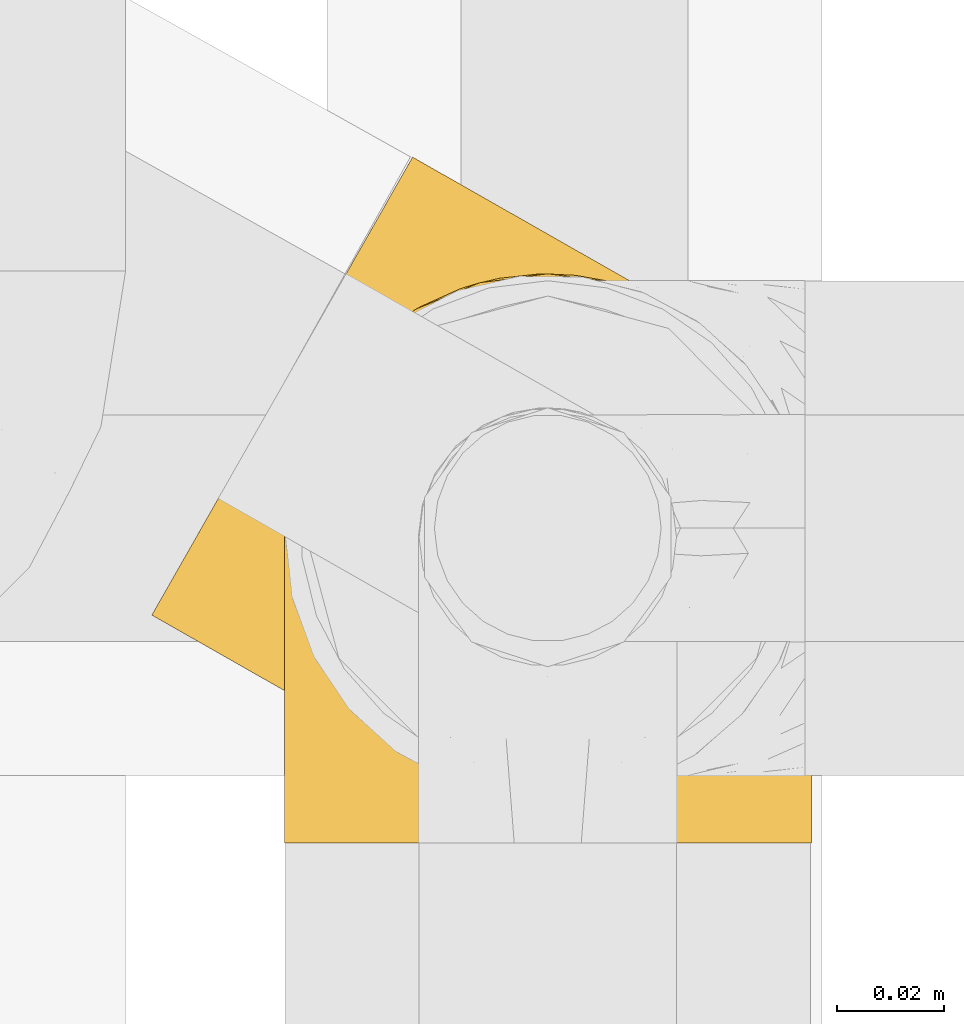
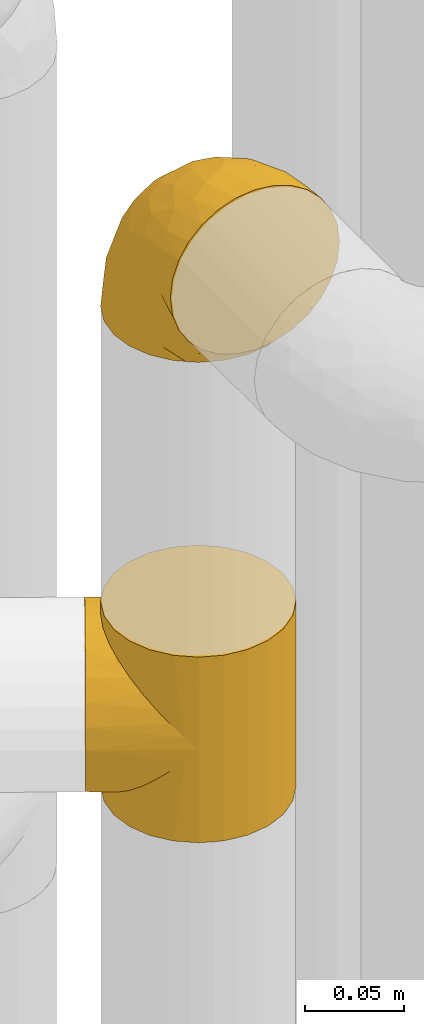
# One storey, part 169 of 827: 2 coverings.
"""IFC2X3 building model written with IfcOpenShell, lengths in millimetres."""

from ifc_helpers import new_model, entity, si_unit, converted_unit, derived_unit, direction, frame, origin, place, context, subcontext, project, spatial, faceted_brep, element, save


model = new_model("IFC2X3")

# Units and contexts
model_context = context("Model", 3, precision=0.01, world=origin(), true_north=direction((6.12303176911189e-17, 1.0)))
body_context = subcontext(model_context, "Body", "Model", "MODEL_VIEW")
ifc_project = project(units=[si_unit("LENGTHUNIT", "METRE", prefix="MILLI"), si_unit("AREAUNIT", "SQUARE_METRE"), si_unit("VOLUMEUNIT", "CUBIC_METRE"), converted_unit("PLANEANGLEUNIT", "DEGREE", entity("IfcRatioMeasure", 0.0174532925199433), si_unit("PLANEANGLEUNIT", "RADIAN"), dimensions=[0, 0, 0, 0, 0, 0, 0]), si_unit("MASSUNIT", "GRAM", prefix="KILO"), derived_unit("MASSDENSITYUNIT", [(si_unit("MASSUNIT", "GRAM", prefix="KILO"), 1), (si_unit("LENGTHUNIT", "METRE"), -3)]), derived_unit("MOMENTOFINERTIAUNIT", [(si_unit("LENGTHUNIT", "METRE"), 4)]), si_unit("TIMEUNIT", "SECOND"), si_unit("FREQUENCYUNIT", "HERTZ"), si_unit("THERMODYNAMICTEMPERATUREUNIT", "DEGREE_CELSIUS"), derived_unit("THERMALTRANSMITTANCEUNIT", [(si_unit("MASSUNIT", "GRAM", prefix="KILO"), 1), (si_unit("THERMODYNAMICTEMPERATUREUNIT", "KELVIN"), -1), (si_unit("TIMEUNIT", "SECOND"), -3)]), derived_unit("VOLUMETRICFLOWRATEUNIT", [(si_unit("LENGTHUNIT", "METRE"), 3), (si_unit("TIMEUNIT", "SECOND"), -1)]), derived_unit("MASSFLOWRATEUNIT", [(si_unit("MASSUNIT", "GRAM", prefix="KILO"), 1), (si_unit("TIMEUNIT", "SECOND"), -1)]), derived_unit("ROTATIONALFREQUENCYUNIT", [(si_unit("TIMEUNIT", "SECOND"), -1)]), si_unit("ELECTRICCURRENTUNIT", "AMPERE"), si_unit("ELECTRICVOLTAGEUNIT", "VOLT"), si_unit("POWERUNIT", "WATT"), si_unit("FORCEUNIT", "NEWTON", prefix="KILO"), si_unit("ILLUMINANCEUNIT", "LUX"), si_unit("LUMINOUSFLUXUNIT", "LUMEN"), si_unit("LUMINOUSINTENSITYUNIT", "CANDELA"), derived_unit("USERDEFINED", [(si_unit("MASSUNIT", "GRAM", prefix="KILO"), -1), (si_unit("LENGTHUNIT", "METRE"), -2), (si_unit("TIMEUNIT", "SECOND"), 3), (si_unit("LUMINOUSFLUXUNIT", "LUMEN"), 1)]), derived_unit("LINEARVELOCITYUNIT", [(si_unit("LENGTHUNIT", "METRE"), 1), (si_unit("TIMEUNIT", "SECOND"), -1)]), si_unit("PRESSUREUNIT", "PASCAL"), derived_unit("USERDEFINED", [(si_unit("LENGTHUNIT", "METRE"), -2), (si_unit("MASSUNIT", "GRAM", prefix="KILO"), 1), (si_unit("TIMEUNIT", "SECOND"), -2)]), derived_unit("LINEARFORCEUNIT", [(si_unit("MASSUNIT", "GRAM", prefix="KILO"), 1), (si_unit("LENGTHUNIT", "METRE"), 1), (si_unit("TIMEUNIT", "SECOND"), -2), (si_unit("LENGTHUNIT", "METRE"), -1)]), derived_unit("PLANARFORCEUNIT", [(si_unit("MASSUNIT", "GRAM", prefix="KILO"), 1), (si_unit("LENGTHUNIT", "METRE"), 1), (si_unit("TIMEUNIT", "SECOND"), -2), (si_unit("LENGTHUNIT", "METRE"), -2)])], contexts=[model_context])

# Site, building, storey
site_placement = place(None, origin())
site = spatial("IfcSite", under=ifc_project, at=site_placement, CompositionType="ELEMENT")
building_placement = place(site_placement, origin())
building = spatial("IfcBuilding", under=site, at=building_placement, CompositionType="ELEMENT")
storey_placement = place(building_placement, frame((0.0, 0.0, 28200.0)))
storey = spatial("IfcBuildingStorey", under=building, at=storey_placement, Name="08", CompositionType="ELEMENT", Elevation=28200.0)

# Coverings
covering_1_placement = place(storey_placement, frame((35649.59, 12703.72, 2248.0)))
element("IfcCovering", 1, at=covering_1_placement, inside=storey, Name=":ADSK_", ObjectType=":ADSK_", PredefinedType="INSULATION", context=body_context, shape_type="Brep", body=[
    faceted_brep([(93.79, 96.34, 50.38), (99.76, 93.46, 0.0), (87.88, 98.3, 0.0), (75.15, 99.89, 0.0), (80.71, 99.61, 37.4), (66.46, 99.07, 25.28), (62.44, 98.14, 0.0), (73.7, 99.86, 31.18), (99.76, 93.46, 57.0), (93.79, 96.34, 63.62), (99.76, 93.46, 114.0), (35.42, 78.88, 8.29), (36.61, 80.17, 0.0), (34.67, 77.62, 0.0), (87.43, 98.41, 43.83), (32.73, 75.06, 7.85), (32.73, 75.06, 0.0), (34.67, 77.62, 114.0), (32.73, 75.06, 106.15), (32.73, 75.06, 114.0), (59.07, 97.09, 19.84), (50.62, 93.16, 0.0), (45.55, 89.22, 0.0), (40.48, 85.29, 0.0), (41.34, 85.85, 10.0), (38.11, 82.7, 8.74), (51.69, 93.77, 15.07), (44.58, 89.0, 11.25), (38.55, 82.73, 0.0), (31.52, 72.09, 0.0), (30.32, 69.12, 0.0), (30.66, 70.32, 8.4), (28.59, 65.57, 8.94), (29.11, 66.15, 0.0), (27.9, 63.18, 0.0), (26.56, 55.83, 12.0), (27.1, 56.81, 0.0), (26.3, 50.45, 0.0), (27.57, 60.7, 10.47), (26.48, 46.46, 16.57), (27.17, 44.09, 0.0), (28.03, 37.82, 22.18), (26.52, 51.14, 14.29), (31.7, 72.69, 8.12), (28.05, 37.74, 0.0), (30.87, 30.04, 28.5), (33.03, 25.91, 0.0), (34.77, 23.16, 35.29), (40.9, 15.78, 0.0), (45.02, 12.15, 49.65), (51.13, 8.03, 0.0), (31.7, 72.69, 105.88), (39.53, 17.2, 42.38), (51.13, 8.03, 57.0), (45.02, 12.15, 64.35), (51.13, 8.03, 114.0), (100.28, 8.33, 114.0), (110.41, 16.2, 114.0), (118.16, 26.43, 114.0), (123.0, 38.31, 114.0), (124.6, 51.04, 114.0), (122.84, 63.75, 114.0), (117.86, 75.58, 114.0), (109.99, 85.71, 114.0), (87.88, 98.3, 114.0), (75.15, 99.89, 114.0), (62.44, 98.14, 114.0), (50.62, 93.16, 114.0), (45.55, 89.22, 114.0), (40.48, 85.29, 114.0), (38.55, 82.73, 114.0), (36.61, 80.17, 114.0), (31.52, 72.09, 114.0), (30.32, 69.12, 114.0), (29.11, 66.15, 114.0), (27.9, 63.18, 114.0), (27.1, 56.81, 114.0), (26.3, 50.45, 114.0), (27.17, 44.09, 114.0), (28.05, 37.74, 114.0), (33.03, 25.91, 114.0), (40.9, 15.78, 114.0), (63.01, 3.19, 114.0), (75.74, 1.6, 114.0), (88.45, 3.35, 114.0), (109.99, 85.71, 0.0), (117.86, 75.58, 0.0), (122.84, 63.75, 0.0), (124.6, 51.04, 0.0), (123.0, 38.31, 0.0), (118.16, 26.43, 0.0), (110.41, 16.2, 0.0), (100.28, 8.33, 0.0), (88.45, 3.35, 0.0), (75.74, 1.6, 0.0), (63.01, 3.19, 0.0), (87.43, 98.41, 70.17), (80.71, 99.61, 76.6), (35.42, 78.88, 105.71), (73.7, 99.86, 82.82), (66.46, 99.07, 88.72), (38.11, 82.7, 105.26), (59.07, 97.09, 94.16), (51.69, 93.77, 98.93), (41.34, 85.85, 104.0), (44.58, 89.0, 102.75), (26.56, 55.83, 102.0), (27.57, 60.7, 103.53), (26.48, 46.46, 97.43), (28.59, 65.57, 105.06), (28.03, 37.82, 91.82), (26.52, 51.14, 99.71), (30.66, 70.32, 105.6), (34.77, 23.16, 78.71), (39.53, 17.2, 71.62), (30.87, 30.04, 85.5), (49.4, 120.2, 44.28), (46.97, 115.94, 32.42), (43.11, 109.15, 22.25), (38.07, 100.3, 14.43), (35.14, 95.15, 11.98), (32.21, 90.0, 9.52), (30.63, 87.24, 9.11), (29.06, 84.47, 8.69), (27.49, 81.71, 8.27), (25.91, 78.95, 7.85), (24.34, 76.18, 8.27), (22.77, 73.42, 8.69), (21.19, 70.65, 9.11), (19.62, 67.89, 9.52), (16.69, 62.74, 11.98), (13.75, 57.59, 14.43), (11.24, 53.17, 18.34), (8.72, 48.74, 22.25), (4.85, 41.96, 32.42), (2.42, 37.69, 44.28), (1.6, 36.23, 57.0), (2.42, 37.69, 69.72), (4.85, 41.96, 81.57), (8.72, 48.74, 91.75), (11.24, 53.17, 95.66), (13.75, 57.59, 99.57), (16.69, 62.74, 102.02), (19.62, 67.89, 104.48), (21.19, 70.65, 104.89), (22.77, 73.42, 105.31), (24.34, 76.18, 105.73), (25.91, 78.95, 106.15), (27.49, 81.71, 105.73), (29.06, 84.47, 105.31), (30.63, 87.24, 104.89), (32.21, 90.0, 104.48), (35.14, 95.15, 102.02), (38.07, 100.3, 99.57), (43.11, 109.15, 91.75), (46.97, 115.94, 81.57), (49.4, 120.2, 69.72), (50.23, 121.66, 57.0)], [[[0, 1, 2]], [[2, 3, 4]], [[5, 3, 6]], [[5, 7, 3]], [[0, 8, 1]], [[8, 9, 10]], [[11, 12, 13]], [[4, 14, 2]], [[7, 4, 3]], [[0, 2, 14]], [[15, 13, 16]], [[17, 18, 19]], [[20, 6, 21]], [[22, 23, 24]], [[15, 11, 13]], [[23, 25, 24]], [[26, 20, 21]], [[27, 21, 22]], [[27, 22, 24]], [[25, 12, 11]], [[25, 23, 28, 12]], [[26, 21, 27]], [[6, 20, 5]], [[29, 30, 31]], [[32, 30, 33, 34]], [[35, 36, 37]], [[38, 36, 35]], [[38, 32, 34]], [[39, 37, 40]], [[41, 39, 40]], [[35, 37, 39, 42]], [[43, 16, 29]], [[40, 44, 41]], [[45, 44, 46]], [[47, 46, 48]], [[49, 48, 50]], [[47, 45, 46]], [[16, 43, 15]], [[51, 19, 18]], [[49, 52, 48]], [[53, 49, 50]], [[54, 53, 55]], [[30, 32, 31]], [[47, 48, 52]], [[36, 38, 34]], [[44, 45, 41]], [[29, 31, 43]], [[56, 57, 58, 59, 60, 61, 62, 63, 10, 64, 65, 66, 67, 68, 69, 70, 71, 17, 19, 72, 73, 74, 75, 76, 77, 78, 79, 80, 81, 55, 82, 83, 84]], [[85, 86, 87, 88, 89, 90, 91, 92, 93, 94, 95, 50, 48, 46, 44, 40, 37, 36, 34, 33, 30, 29, 16, 13, 12, 28, 23, 22, 21, 6, 3, 2, 1]], [[88, 87, 61, 60]], [[58, 90, 89, 59]], [[89, 88, 60, 59]], [[62, 86, 85, 63]], [[1, 8, 10, 63, 85]], [[61, 87, 86, 62]], [[96, 97, 64]], [[18, 17, 98]], [[9, 96, 64]], [[10, 9, 64]], [[65, 99, 100]], [[65, 64, 97]], [[71, 101, 98]], [[65, 100, 66]], [[99, 65, 97]], [[102, 103, 67]], [[104, 68, 105]], [[104, 101, 69]], [[68, 104, 69]], [[103, 105, 67]], [[66, 102, 67]], [[101, 71, 70, 69]], [[68, 67, 105]], [[98, 17, 71]], [[102, 66, 100]], [[106, 76, 107]], [[106, 77, 76]], [[77, 108, 78]], [[109, 75, 74, 73]], [[110, 78, 108]], [[111, 108, 77, 106]], [[19, 51, 72]], [[109, 73, 112]], [[72, 51, 112]], [[76, 75, 107]], [[110, 79, 78]], [[75, 109, 107]], [[113, 114, 81]], [[114, 54, 81]], [[79, 115, 80]], [[115, 79, 110]], [[113, 80, 115]], [[113, 81, 80]], [[54, 55, 81]], [[112, 73, 72]], [[53, 50, 95, 82, 55]], [[82, 95, 94, 83]], [[94, 93, 84, 83]], [[84, 93, 92, 56]], [[56, 92, 91, 57]], [[57, 91, 90, 58]], [[116, 117, 118, 119, 120, 121, 122, 123, 124, 125, 126, 127, 128, 129, 130, 131, 132, 133, 134, 135, 136, 137, 138, 139, 140, 141, 142, 143, 144, 145, 146, 147, 148, 149, 150, 151, 152, 153, 154, 155, 156, 157]], [[25, 123, 122, 121]], [[119, 118, 20]], [[15, 124, 11]], [[27, 120, 119]], [[124, 15, 125]], [[124, 123, 11]], [[120, 24, 121]], [[26, 27, 119]], [[20, 26, 119]], [[24, 120, 27]], [[25, 121, 24]], [[118, 5, 20]], [[7, 5, 117]], [[117, 5, 118]], [[4, 117, 116]], [[0, 116, 157]], [[4, 7, 117]], [[0, 14, 116]], [[8, 0, 157]], [[4, 116, 14]], [[123, 25, 11]], [[9, 157, 156]], [[156, 155, 97]], [[100, 155, 154]], [[100, 99, 155]], [[9, 8, 157]], [[98, 149, 148]], [[97, 96, 156]], [[99, 97, 155]], [[9, 156, 96]], [[18, 148, 147]], [[102, 154, 153]], [[152, 151, 104]], [[18, 98, 148]], [[151, 101, 104]], [[103, 102, 153]], [[105, 153, 152]], [[105, 152, 104]], [[101, 149, 98]], [[101, 151, 150, 149]], [[103, 153, 105]], [[154, 102, 100]], [[146, 145, 112]], [[109, 145, 144, 143]], [[106, 142, 141]], [[107, 142, 106]], [[107, 109, 143]], [[108, 141, 140]], [[110, 108, 140]], [[106, 141, 108, 111]], [[51, 147, 146]], [[140, 139, 110]], [[115, 139, 138]], [[113, 138, 137]], [[54, 137, 136]], [[113, 115, 138]], [[147, 51, 18]], [[54, 114, 137]], [[53, 54, 136]], [[145, 109, 112]], [[113, 137, 114]], [[142, 107, 143]], [[139, 115, 110]], [[146, 112, 51]], [[49, 136, 135]], [[135, 134, 47]], [[45, 134, 133]], [[45, 47, 134]], [[43, 125, 15]], [[49, 53, 136]], [[32, 129, 128, 127]], [[47, 52, 135]], [[49, 135, 52]], [[31, 127, 126]], [[131, 35, 42, 39]], [[125, 43, 126]], [[39, 132, 131]], [[130, 129, 38]], [[43, 31, 126]], [[41, 133, 132]], [[41, 132, 39]], [[35, 130, 38]], [[32, 127, 31]], [[35, 131, 130]], [[129, 32, 38]], [[133, 41, 45]]]),
])
covering_2_placement = place(storey_placement, frame((35674.29, 12695.87, 2541.4)))
element("IfcCovering", 2, at=covering_2_placement, inside=storey, Name=":ADSK_", ObjectType=":ADSK_", PredefinedType="INSULATION", context=body_context, shape_type="Brep", body=[
    faceted_brep([(99.9, 1.6, 58.6), (98.66, 1.6, 69.54), (95.02, 1.6, 79.93), (89.17, 1.6, 89.25), (81.38, 1.6, 97.03), (72.06, 1.6, 102.88), (61.68, 1.6, 106.51), (50.75, 1.6, 107.75), (39.8, 1.6, 106.51), (29.41, 1.6, 102.87), (20.09, 1.6, 97.02), (12.31, 1.6, 89.23), (6.46, 1.6, 79.91), (2.83, 1.6, 69.53), (1.6, 1.6, 58.6), (2.24, 1.6, 52.89), (2.83, 1.6, 47.65), (4.65, 1.6, 42.46), (6.47, 1.6, 37.26), (12.32, 1.6, 27.94), (20.11, 1.6, 20.16), (29.43, 1.6, 14.31), (39.81, 1.6, 10.68), (50.75, 1.6, 9.45), (61.69, 1.6, 10.68), (72.08, 1.6, 14.32), (81.4, 1.6, 20.17), (89.18, 1.6, 27.96), (95.03, 1.6, 37.28), (96.85, 1.6, 42.47), (98.66, 1.6, 47.66), (99.25, 1.6, 52.89), (99.57, 1.6, 55.75), (38.02, 11.12, 1.6), (26.17, 16.03, 1.6), (21.08, 19.94, 1.6), (15.99, 23.84, 1.6), (12.09, 28.93, 1.6), (8.18, 34.02, 1.6), (5.73, 39.95, 1.6), (3.27, 45.87, 1.6), (2.35, 52.86, 1.6), (1.97, 55.73, 1.6), (1.6, 58.6, 1.6), (3.27, 71.32, 1.6), (8.18, 83.17, 1.6), (15.99, 93.35, 1.6), (26.17, 101.16, 1.6), (38.02, 106.07, 1.6), (50.75, 107.75, 1.6), (63.47, 106.07, 1.6), (75.32, 101.16, 1.6), (85.5, 93.35, 1.6), (93.31, 83.17, 1.6), (98.22, 71.32, 1.6), (99.9, 58.6, 1.6), (99.14, 52.86, 1.6), (98.22, 45.87, 1.6), (95.77, 39.95, 1.6), (93.31, 34.02, 1.6), (89.4, 28.93, 1.6), (85.5, 23.84, 1.6), (80.41, 19.94, 1.6), (75.32, 16.03, 1.6), (63.47, 11.12, 1.6), (50.75, 9.45, 1.6), (59.31, 81.82, 69.96), (73.08, 84.02, 59.59), (63.72, 93.05, 51.96), (50.75, 102.55, 34.4), (58.64, 104.83, 23.37), (50.75, 105.83, 13.68), (76.74, 91.87, 41.52), (67.68, 101.74, 26.26), (78.92, 97.07, 20.18), (94.31, 38.45, 72.33), (98.76, 22.17, 65.88), (98.4, 42.04, 57.55), (94.57, 77.69, 23.76), (89.91, 75.76, 46.5), (96.32, 62.11, 46.57), (98.79, 66.08, 21.17), (99.9, 54.26, 23.41), (99.9, 55.35, 17.92), (99.9, 56.44, 12.43), (99.9, 56.98, 9.72), (99.9, 57.52, 7.01), (87.31, 87.84, 26.77), (95.61, 19.41, 76.59), (60.43, 48.89, 95.55), (65.24, 26.34, 102.57), (72.87, 44.55, 92.89), (99.9, 23.41, 54.26), (99.9, 28.03, 51.17), (99.9, 32.65, 48.08), (99.9, 37.28, 44.99), (99.9, 41.9, 41.9), (90.65, 20.6, 85.16), (63.14, 63.36, 85.97), (91.89, 62.21, 59.58), (75.25, 19.94, 99.5), (50.75, 13.68, 105.83), (82.18, 80.85, 53.59), (85.08, 66.53, 67.0), (76.93, 71.06, 71.56), (50.75, 63.99, 87.47), (50.75, 75.73, 75.73), (83.02, 26.77, 92.24), (99.9, 4.31, 58.06), (99.9, 7.01, 57.52), (99.9, 12.43, 56.44), (99.9, 17.92, 55.35), (87.13, 43.43, 81.33), (80.85, 56.23, 80.35), (99.17, 54.97, 39.44), (50.75, 34.4, 102.55), (99.9, 44.99, 37.28), (99.9, 48.08, 32.65), (99.9, 51.17, 28.03), (50.75, 87.47, 63.99), (67.61, 74.55, 74.55), (72.25, 60.86, 83.62), (50.75, 49.19, 95.01), (50.75, 95.01, 49.19), (98.69, 10.27, 46.96), (99.01, 48.79, 8.77), (98.79, 45.16, 18.28), (98.29, 44.99, 11.68), (68.51, 6.17, 11.79), (76.82, 7.65, 15.69), (98.54, 21.59, 42.49), (99.3, 19.96, 47.41), (83.57, 21.0, 7.94), (89.47, 27.2, 9.27), (75.76, 14.83, 7.98), (84.86, 19.7, 13.4), (75.89, 10.93, 13.04), (64.77, 9.63, 7.36), (90.83, 19.97, 23.46), (94.62, 21.13, 30.46), (90.37, 14.14, 26.54), (91.18, 30.2, 6.76), (88.65, 8.12, 26.46), (84.11, 9.93, 20.77), (91.75, 24.62, 20.68), (96.86, 11.87, 40.26), (50.75, 7.15, 7.15), (58.97, 5.32, 9.28), (98.37, 26.68, 38.78), (83.91, 13.92, 18.27), (97.52, 30.67, 31.78), (95.55, 36.65, 12.75), (98.76, 42.89, 22.96), (95.26, 34.04, 17.55), (98.04, 36.6, 27.63), (90.65, 26.41, 15.23), (93.51, 10.07, 33.25), (94.16, 15.83, 32.43), (99.1, 41.99, 27.9), (25.73, 14.83, 7.97), (10.84, 26.4, 15.22), (17.92, 21.01, 7.93), (16.64, 19.71, 13.38), (30.44, 5.72, 13.12), (2.95, 21.6, 42.49), (2.19, 19.96, 47.4), (1.6, 28.03, 51.17), (4.63, 11.87, 40.24), (17.39, 9.93, 20.76), (1.6, 56.44, 12.43), (1.6, 57.52, 7.01), (1.6, 58.06, 4.31), (12.86, 8.13, 26.44), (11.13, 14.15, 26.52), (3.2, 44.99, 11.68), (5.94, 36.65, 12.75), (12.02, 27.21, 9.27), (6.23, 34.04, 17.55), (10.31, 30.2, 6.76), (8.0, 10.06, 33.21), (7.34, 15.83, 32.41), (2.48, 48.79, 8.77), (2.73, 42.89, 22.96), (2.64, 45.38, 18.48), (1.6, 12.43, 56.44), (2.8, 10.28, 46.95), (36.71, 9.64, 7.36), (1.6, 55.35, 17.92), (1.6, 54.26, 23.41), (38.59, 6.05, 9.85), (1.6, 7.01, 57.52), (1.6, 9.72, 56.98), (1.6, 32.65, 48.08), (3.12, 26.68, 38.78), (17.59, 13.92, 18.25), (1.6, 37.28, 44.99), (3.98, 30.66, 31.74), (6.87, 21.14, 30.45), (3.45, 36.59, 27.63), (9.76, 24.6, 20.65), (1.6, 17.92, 55.35), (1.6, 23.41, 54.26), (25.62, 10.93, 13.03), (10.67, 19.97, 23.44), (2.39, 41.99, 27.9), (1.6, 48.08, 32.65), (1.6, 51.17, 28.03), (1.6, 44.99, 37.28), (1.6, 41.9, 41.9), (2.4, 55.26, 39.74), (42.85, 104.83, 23.37), (14.18, 87.84, 26.77), (11.56, 75.91, 46.18), (19.27, 80.84, 53.54), (24.75, 91.87, 41.53), (28.37, 83.98, 59.61), (5.95, 19.16, 76.79), (2.79, 22.37, 66.11), (2.71, 66.08, 21.17), (37.78, 93.05, 51.96), (33.81, 101.74, 26.26), (22.57, 97.07, 20.18), (6.92, 77.69, 23.76), (28.61, 44.55, 92.88), (36.24, 26.34, 102.57), (41.05, 48.9, 95.54), (24.55, 70.99, 71.63), (33.88, 74.55, 74.55), (7.11, 37.8, 72.51), (42.18, 81.82, 69.96), (18.46, 26.77, 92.23), (10.84, 20.6, 85.15), (20.69, 56.15, 80.45), (29.27, 60.85, 83.65), (3.1, 42.06, 57.57), (9.18, 57.03, 63.68), (38.38, 63.4, 85.95), (26.23, 19.94, 99.49), (14.34, 43.59, 81.23), (5.46, 62.61, 47.07), (16.39, 66.52, 66.99)], [[[0, 1, 2, 3, 4, 5, 6, 7, 8, 9, 10, 11, 12, 13, 14, 15, 16, 17, 18, 19, 20, 21, 22, 23, 24, 25, 26, 27, 28, 29, 30, 31, 32]], [[33, 34, 35, 36, 37, 38, 39, 40, 41, 42, 43, 44, 45, 46, 47, 48, 49, 50, 51, 52, 53, 54, 55, 56, 57, 58, 59, 60, 61, 62, 63, 64, 65]], [[66, 67, 68]], [[69, 70, 71]], [[68, 72, 73]], [[73, 72, 74]], [[75, 76, 77]], [[78, 79, 80]], [[51, 50, 73]], [[81, 82, 83, 84, 85, 86, 55]], [[52, 87, 53]], [[74, 52, 51]], [[2, 1, 88]], [[89, 90, 91]], [[77, 92, 93, 94, 95, 96]], [[55, 54, 81]], [[78, 53, 87]], [[5, 90, 6]], [[88, 76, 75]], [[97, 3, 2]], [[89, 91, 98]], [[99, 80, 79]], [[90, 5, 100]], [[74, 87, 52]], [[100, 5, 4]], [[90, 101, 6]], [[79, 102, 103]], [[102, 67, 104]], [[105, 98, 106]], [[107, 4, 3]], [[76, 0, 108, 109, 110, 111, 92]], [[107, 112, 113]], [[114, 77, 96]], [[89, 115, 90]], [[114, 96, 116, 117, 118, 82]], [[75, 97, 88]], [[119, 66, 68]], [[50, 71, 70]], [[100, 91, 90]], [[99, 77, 80]], [[102, 104, 103]], [[97, 107, 3]], [[80, 81, 78]], [[107, 97, 112]], [[68, 73, 70]], [[66, 98, 120]], [[78, 81, 54]], [[114, 81, 80]], [[53, 78, 54]], [[78, 87, 79]], [[102, 87, 72]], [[79, 103, 99]], [[4, 107, 100]], [[91, 100, 107]], [[88, 97, 2]], [[112, 97, 75]], [[99, 112, 75]], [[103, 104, 113]], [[91, 121, 98]], [[89, 105, 122, 115]], [[101, 90, 115]], [[101, 7, 6]], [[88, 1, 76]], [[0, 76, 1]], [[92, 77, 76]], [[73, 74, 51]], [[87, 74, 72]], [[81, 114, 82]], [[77, 114, 80]], [[87, 102, 79]], [[67, 102, 72]], [[68, 67, 72]], [[67, 120, 104]], [[120, 121, 104]], [[104, 121, 113]], [[121, 120, 98]], [[91, 107, 113]], [[91, 113, 121]], [[103, 113, 112]], [[106, 98, 66]], [[105, 89, 98]], [[106, 66, 119]], [[67, 66, 120]], [[68, 69, 123, 119]], [[50, 49, 71]], [[50, 70, 73]], [[112, 99, 103]], [[77, 99, 75]], [[69, 68, 70]], [[29, 124, 110]], [[84, 83, 125]], [[126, 82, 118]], [[59, 58, 127]], [[25, 128, 129]], [[130, 93, 131]], [[132, 62, 133]], [[134, 135, 136]], [[137, 65, 64]], [[64, 134, 137]], [[138, 139, 140]], [[111, 110, 124, 92]], [[134, 136, 137]], [[134, 64, 63]], [[141, 61, 60]], [[125, 58, 57]], [[142, 143, 140]], [[142, 26, 143]], [[127, 83, 82]], [[28, 124, 29]], [[108, 0, 32, 31, 30, 110, 109]], [[30, 29, 110]], [[135, 144, 138]], [[28, 145, 124]], [[57, 56, 55, 86, 85, 84]], [[146, 147, 23]], [[24, 23, 147]], [[25, 143, 26]], [[95, 94, 148]], [[24, 128, 25]], [[149, 138, 143]], [[124, 145, 131]], [[127, 58, 125]], [[150, 148, 139]], [[127, 126, 151]], [[151, 59, 127]], [[152, 151, 126]], [[153, 154, 155]], [[153, 133, 141]], [[145, 28, 27]], [[142, 156, 27]], [[157, 148, 130]], [[61, 133, 62]], [[134, 132, 135]], [[147, 128, 24]], [[65, 137, 146]], [[146, 137, 147]], [[128, 137, 136]], [[137, 128, 147]], [[128, 136, 129]], [[149, 129, 136]], [[25, 129, 143]], [[158, 152, 117]], [[152, 118, 117]], [[153, 151, 152]], [[158, 116, 154]], [[144, 150, 138]], [[153, 152, 158]], [[133, 153, 155]], [[133, 155, 132]], [[141, 60, 151]], [[135, 132, 155]], [[134, 63, 132]], [[144, 135, 155]], [[135, 138, 149]], [[155, 154, 144]], [[150, 154, 96]], [[154, 150, 144]], [[148, 94, 130]], [[82, 126, 127]], [[118, 152, 126]], [[150, 96, 95]], [[139, 148, 157]], [[150, 95, 148]], [[93, 92, 131]], [[130, 145, 156]], [[130, 94, 93]], [[84, 125, 57]], [[127, 125, 83]], [[140, 139, 157]], [[150, 139, 138]], [[140, 157, 142]], [[138, 140, 143]], [[156, 142, 157]], [[27, 26, 142]], [[130, 156, 157]], [[145, 27, 156]], [[132, 63, 62]], [[124, 131, 92]], [[130, 131, 145]], [[129, 149, 143]], [[135, 149, 136]], [[153, 141, 151]], [[59, 151, 60]], [[133, 61, 141]], [[116, 96, 154]], [[153, 158, 154]], [[158, 117, 116]], [[34, 33, 159]], [[160, 161, 162]], [[22, 21, 163]], [[164, 165, 166]], [[19, 18, 167]], [[168, 21, 20]], [[42, 41, 40, 169, 170, 171, 43]], [[172, 173, 168]], [[174, 38, 175]], [[176, 177, 178]], [[179, 164, 180]], [[40, 181, 169]], [[182, 183, 175]], [[17, 184, 185]], [[65, 146, 186]], [[187, 174, 188]], [[23, 22, 189]], [[174, 39, 38]], [[15, 14, 190, 191, 184, 16]], [[181, 40, 39]], [[192, 193, 164]], [[194, 163, 168]], [[33, 186, 159]], [[180, 173, 172]], [[195, 196, 193]], [[18, 185, 167]], [[173, 180, 197]], [[198, 199, 196]], [[200, 201, 185, 184]], [[184, 17, 16]], [[18, 17, 185]], [[202, 159, 186]], [[194, 168, 203]], [[189, 163, 202]], [[204, 205, 182]], [[187, 181, 174]], [[160, 177, 176]], [[206, 183, 182]], [[206, 182, 205]], [[201, 165, 185]], [[165, 164, 167]], [[172, 179, 180]], [[202, 194, 162]], [[176, 161, 160]], [[65, 186, 33]], [[163, 189, 22]], [[175, 177, 182]], [[174, 183, 188]], [[177, 198, 204]], [[199, 160, 162]], [[198, 207, 204]], [[175, 38, 37]], [[198, 177, 160]], [[178, 177, 175]], [[176, 35, 161]], [[34, 159, 161]], [[162, 161, 159]], [[202, 162, 159]], [[199, 162, 203]], [[196, 199, 203]], [[198, 160, 199]], [[193, 197, 180]], [[208, 198, 196]], [[188, 183, 206]], [[175, 183, 174]], [[193, 192, 195]], [[195, 208, 196]], [[197, 196, 203]], [[180, 164, 193]], [[168, 163, 21]], [[166, 165, 201]], [[166, 192, 164]], [[189, 202, 186]], [[186, 146, 189]], [[23, 189, 146]], [[174, 181, 39]], [[169, 181, 187]], [[196, 197, 193]], [[173, 203, 168]], [[203, 173, 197]], [[172, 168, 20]], [[20, 19, 172]], [[179, 172, 19]], [[19, 167, 179]], [[164, 179, 167]], [[35, 176, 36]], [[35, 34, 161]], [[185, 165, 167]], [[162, 194, 203]], [[163, 194, 202]], [[176, 178, 36]], [[37, 36, 178]], [[175, 37, 178]], [[177, 204, 182]], [[207, 198, 208]], [[207, 205, 204]], [[209, 188, 206, 205, 207, 208]], [[48, 210, 71]], [[211, 212, 213]], [[214, 213, 215]], [[216, 217, 13]], [[218, 43, 171, 170, 169, 187, 188]], [[219, 220, 214]], [[47, 46, 221]], [[210, 48, 220]], [[211, 222, 212]], [[222, 45, 44]], [[221, 220, 47]], [[47, 220, 48]], [[221, 211, 214]], [[223, 224, 225]], [[211, 46, 45]], [[226, 227, 215]], [[43, 218, 44]], [[217, 216, 228]], [[219, 215, 229]], [[14, 13, 217]], [[224, 9, 8]], [[10, 230, 11]], [[11, 231, 12]], [[232, 223, 233]], [[234, 208, 195, 192, 166, 201]], [[235, 234, 228]], [[222, 44, 218]], [[106, 229, 236]], [[224, 237, 9]], [[231, 238, 228]], [[9, 237, 10]], [[115, 224, 101]], [[239, 234, 235]], [[231, 11, 230]], [[223, 230, 237]], [[224, 8, 101]], [[223, 236, 233]], [[225, 115, 122, 105]], [[216, 12, 231]], [[209, 234, 239]], [[210, 219, 69]], [[219, 214, 215]], [[229, 119, 219]], [[209, 218, 188]], [[239, 212, 222]], [[239, 222, 218]], [[45, 222, 211]], [[235, 212, 239]], [[213, 212, 240]], [[223, 237, 224]], [[230, 10, 237]], [[238, 231, 230]], [[216, 231, 228]], [[232, 230, 223]], [[235, 238, 240]], [[115, 225, 224]], [[233, 236, 227]], [[8, 7, 101]], [[234, 209, 208]], [[218, 209, 239]], [[217, 228, 234]], [[13, 12, 216]], [[234, 201, 217]], [[217, 201, 200, 184, 191, 190, 14]], [[211, 221, 46]], [[220, 221, 214]], [[71, 210, 69]], [[71, 49, 48]], [[219, 210, 220]], [[226, 215, 213]], [[211, 213, 214]], [[226, 213, 240]], [[215, 227, 229]], [[232, 240, 238]], [[233, 227, 226]], [[232, 233, 226]], [[236, 223, 225]], [[240, 232, 226]], [[232, 238, 230]], [[225, 105, 236]], [[236, 105, 106]], [[236, 229, 227]], [[123, 69, 219, 119]], [[106, 119, 229]], [[238, 235, 228]], [[212, 235, 240]]]),
])

save(model, "model.ifc")
